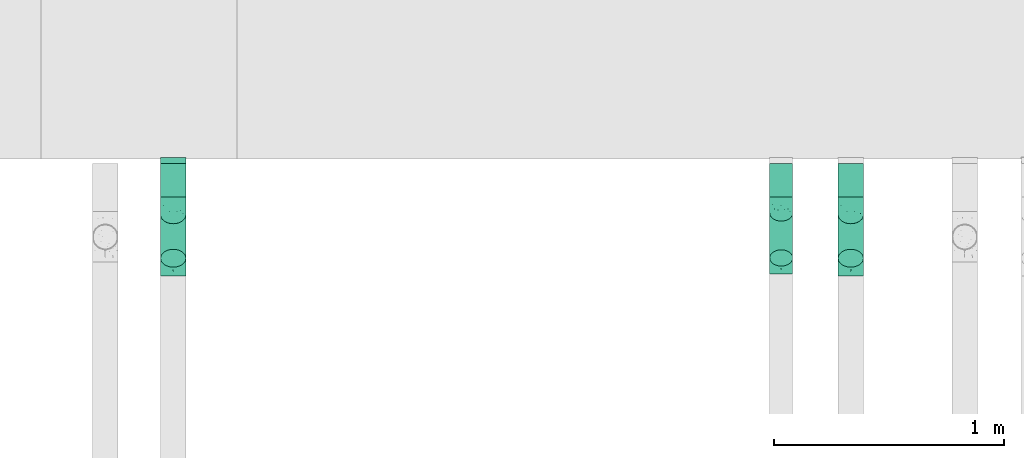
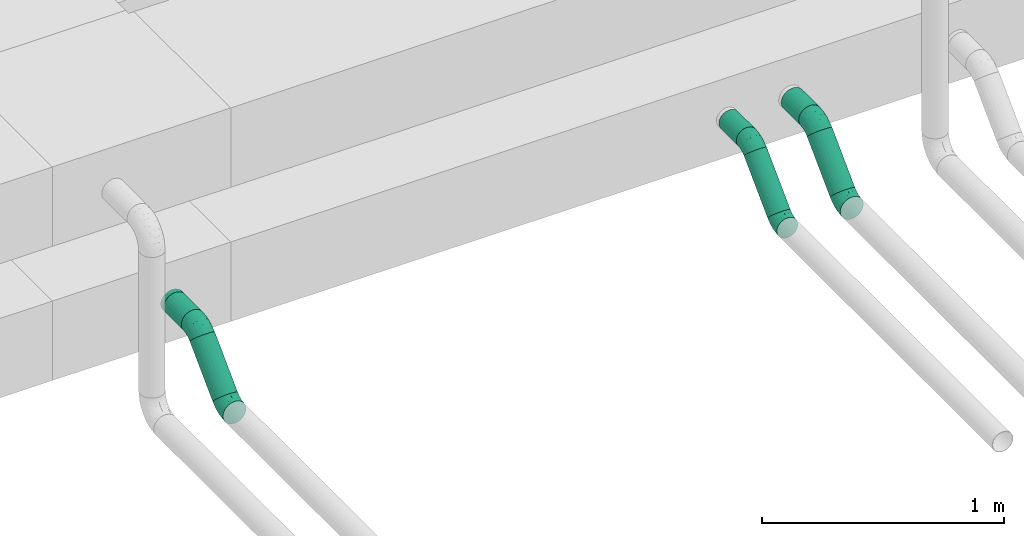
# One storey, part 47 of 91: 7 flow fittings, 6 flow segments.
"""IFC2X3 building model written with IfcOpenShell, lengths in millimetres."""

from ifc_helpers import new_model, entity, si_unit, converted_unit, derived_unit, direction, frame, origin_with_axes, origin_2d_with_axis, place, context, subcontext, project, spatial, hollow_circle, extrude, open_shell, surface_model, source, transform, mapped, material, layer, layer_set, layer_usage, type_object, element, save


model = new_model("IFC2X3")

# Units and contexts
model_context = context("Model", 3, precision=1e-05, world=origin_with_axes(), true_north=direction((0.0, 1.0)))
body_context = subcontext(model_context, "Body", "Model", "MODEL_VIEW")
ifc_project = project(units=[si_unit("AREAUNIT", "SQUARE_METRE"), si_unit("VOLUMEUNIT", "CUBIC_METRE", prefix="DECI"), si_unit("TIMEUNIT", "SECOND"), si_unit("THERMODYNAMICTEMPERATUREUNIT", "DEGREE_CELSIUS"), si_unit("PRESSUREUNIT", "PASCAL"), si_unit("MASSUNIT", "GRAM", prefix="KILO"), si_unit("LENGTHUNIT", "METRE", prefix="MILLI"), si_unit("POWERUNIT", "WATT"), si_unit("ELECTRICCURRENTUNIT", "AMPERE"), si_unit("ELECTRICVOLTAGEUNIT", "VOLT"), derived_unit("VOLUMETRICFLOWRATEUNIT", [(si_unit("VOLUMEUNIT", "CUBIC_METRE", prefix="DECI"), 1), (si_unit("TIMEUNIT", "SECOND"), -1)]), derived_unit("LINEARVELOCITYUNIT", [(si_unit("LENGTHUNIT", "METRE"), 1), (si_unit("TIMEUNIT", "SECOND"), -1)]), derived_unit("MASSDENSITYUNIT", [(si_unit("MASSUNIT", "GRAM", prefix="KILO"), 1), (si_unit("VOLUMEUNIT", "CUBIC_METRE"), -1)]), converted_unit("PLANEANGLEUNIT", "DEGREE", entity("IfcRatioMeasure", 0.01745), si_unit("PLANEANGLEUNIT", "RADIAN"), dimensions=[0, 0, 0, 0, 0, 0, 0])], contexts=[model_context])

# Site, building, storey
site_placement = place(None, origin_with_axes())
site = spatial("IfcSite", under=ifc_project, at=site_placement, CompositionType="ELEMENT")
building_placement = place(site_placement, origin_with_axes())
building = spatial("IfcBuilding", under=site, at=building_placement, Name="mc-building", CompositionType="ELEMENT")
storey_placement = place(building_placement, frame((0.0, 0.0, 8700.0), z_axis=(0.0, 0.0, 1.0), x_axis=(1.0, 0.0, 0.0)))
storey = spatial("IfcBuildingStorey", under=building, at=storey_placement, CompositionType="ELEMENT", Elevation=8700.0)

# Flow segments
ifc_material = material(Name="FZ1")
ifc_layer = layer(ifc_material, 0.0)
ifc_layer_set = layer_set([ifc_layer], Name="FZ1")
ifc_layer_usage = layer_usage(ifc_layer_set, "AXIS1", "POSITIVE", 0.0)
duct_segment_type = type_object("IfcDuctSegmentType", PredefinedType="RIGIDSEGMENT")
shared_shape_1 = source(origin_with_axes(), body_context, "Body", "SweptSolid", [
    extrude(hollow_circle(Radius=55.0, WallThickness=2.0, at=origin_2d_with_axis()), frame((0.0, 0.0, 0.0), z_axis=(1.0, 0.0, 0.0), x_axis=(0.0, 1.0, 0.0)), (0.0, 0.0, 1.0), 266.7),
])
for number, where, z_axis, x_axis in (
    (1, (23048.85991, 2708.27872, 635.78175), (0.0, -0.707107, 0.707107), (0.0, -0.707107, -0.707107)),
    (2, (25991.68775, 2708.27872, 635.78175), (0.0, -0.707107, 0.707107), (0.0, -0.707107, -0.707107)),
):
    element("IfcFlowSegment", number, at=place(storey_placement, frame(where, z_axis=z_axis, x_axis=x_axis)), inside=storey, type_object=duct_segment_type, material=ifc_layer_usage, context=body_context, shape_type="MappedRepresentation", body=[
        mapped(shared_shape_1, transform((0.0, 0.0, 0.0), scale=1.0)),
    ])

# Flow fittings
duct_fitting_type_1 = type_object("IfcDuctFittingType", Name="BU", PredefinedType="BEND")
shared_shape_2 = source(origin_with_axes(), body_context, "Body", "SurfaceModel", [
    surface_model("IfcShellBasedSurfaceModel", [(-45.56349, 0.0, -55.0), (-45.56349, -14.23505, -53.12592), (-45.56349, 14.23505, -53.12592), (-45.56349, 53.12592, 14.23505), (-45.56349, 27.5, -47.63139), (-45.56349, 38.89087, -38.89087), (-45.56349, 47.63139, -27.5), (-45.56349, -55.0, 0.0), (-45.56349, -53.12592, 14.23505), (-45.56349, -38.89087, -38.89087), (-45.56349, -27.5, -47.63139), (-45.56349, -53.12592, -14.23505), (-45.56349, -47.63139, -27.5), (-45.56349, 53.12592, -14.23505), (-45.56349, 47.63139, 27.5), (-45.56349, 38.89087, 38.89087), (-45.56349, -14.23505, 53.12592), (-45.56349, 27.5, 47.63139), (-45.56349, 14.23505, 53.12592), (-45.56349, -47.63139, 27.5), (-45.56349, -38.89087, 38.89087), (-45.56349, -27.5, 47.63139), (-45.56349, 0.0, 55.0), (-45.56349, 55.0, 0.0), (22.15256, 42.28395, -53.12592), (-6.67262, 71.10913, 0.0), (32.21826, 32.21826, -55.0), (12.77282, 51.66369, -47.63139), (-1.46223, 65.89874, -27.5), (4.71825, 59.71825, -38.89087), (59.71825, 4.71825, -38.89087), (69.78395, -5.34744, 14.23505), (51.66369, 12.77282, -47.63139), (42.28395, 22.15256, -53.12592), (65.89874, -1.46223, -27.5), (69.78395, -5.34744, -14.23505), (71.10913, -6.67262, 0.0), (-5.34744, 69.78395, -14.23505), (-5.34744, 69.78395, 14.23505), (-1.46223, 65.89874, 27.5), (4.71825, 59.71825, 38.89087), (32.21826, 32.21826, 55.0), (12.77282, 51.66369, 47.63139), (22.15256, 42.28395, 53.12592), (59.71825, 4.71825, 38.89087), (65.89874, -1.46223, 27.5), (42.28395, 22.15256, 53.12592), (51.66369, 12.77282, 47.63139), (-20.16649, 48.68621, 33.48188), (-26.97111, 35.77503, 43.63444), (-7.30443, 43.73336, 43.63444), (-17.0934, 3.74816, 55.0), (-18.00408, 15.44793, 53.78143), (-30.11707, 22.39897, 50.81337), (-7.49776, 55.63651, 33.48188), (-15.97018, 58.74288, 21.04759), (-31.18231, 52.58712, 21.04759), (-18.35174, 61.03934, 10.51509), (-28.67677, 56.60048, 10.47121), (-34.03924, 44.64267, 33.48188), (-11.52288, 27.81868, 50.81338), (1.19951, 23.16465, 53.81115), (-33.77926, 57.34403, 0.0), (5.4586, 37.12132, 50.81809), (-24.5159, 59.18663, 0.0), (-16.66281, 64.4339, 0.0), (9.43651, 14.73721, 55.0), (-6.22531, 44.36822, -43.63444), (5.4586, 37.12132, -50.81809), (-34.03924, 44.64267, -33.48188), (9.43651, 14.73721, -55.0), (-17.0934, 3.74816, -55.0), (1.19951, 23.16465, -53.81115), (-11.52288, 27.81868, -50.81338), (-30.11707, 22.39897, -50.81337), (-25.75914, 36.08917, -43.63444), (-30.24487, 52.83011, -21.04759), (-20.16649, 48.68621, -33.48188), (-7.49776, 55.63651, -33.48188), (-18.00408, 15.44793, -53.78143), (-28.68366, 56.62226, -10.35271), (-14.15883, 63.53074, -10.87592), (-15.13548, 59.23394, -21.04759), (3.19797, -7.72059, -52.16847), (3.1272, -18.04126, -47.9241), (13.63233, -32.91136, -32.06475), (45.23618, -22.99734, -20.4997), (16.67434, -40.25541, -15.9539), (-17.3935, -51.68264, -9.80849), (-2.85835, -49.37776, 0.0), (48.84421, -24.24609, -9.80849), (-16.38424, -42.76862, -30.85433), (-6.97383, -29.41689, -42.70541), (41.82739, -18.65658, -30.85433), (-15.72523, -48.24839, -20.4997), (29.28945, -13.63928, -42.80781), (26.81493, -3.56603, -49.15704), (36.93651, -32.89419, 0.0), (-15.72523, -48.24839, 20.4997), (-17.3935, -51.68264, 9.80849), (-16.38424, -42.76862, 30.85433), (16.67434, -40.25541, 15.9539), (3.19797, -7.72059, 52.16847), (10.54583, -14.96836, 47.9241), (13.63233, -32.91136, 32.06475), (45.23618, -22.99734, 20.4997), (41.82739, -18.65658, 30.85433), (-11.06635, -30.3552, 42.80781), (25.73213, -15.86964, 42.70541), (-16.43945, -21.48258, 49.15704), (48.84421, -24.24609, 9.80849)], [open_shell([[[0, 1, 2]], [[2, 3, 4]], [[5, 3, 6]], [[4, 3, 5]], [[2, 7, 8]], [[9, 7, 10]], [[1, 10, 7]], [[11, 7, 12]], [[9, 12, 7]], [[7, 2, 1]], [[13, 6, 3]], [[14, 3, 2]], [[15, 14, 2]], [[16, 17, 2]], [[2, 17, 15]], [[16, 18, 17]], [[19, 20, 2]], [[19, 2, 8]], [[20, 21, 2]], [[2, 21, 16]], [[16, 22, 18]], [[23, 13, 3]], [[24, 25, 26]], [[27, 25, 24]], [[28, 25, 29]], [[29, 25, 27]], [[30, 26, 31]], [[26, 30, 32]], [[32, 33, 26]], [[34, 31, 35]], [[31, 34, 30]], [[35, 31, 36]], [[37, 25, 28]], [[26, 38, 39]], [[26, 39, 40]], [[41, 40, 42]], [[26, 40, 41]], [[42, 43, 41]], [[26, 44, 45]], [[31, 26, 45]], [[46, 47, 26]], [[47, 44, 26]], [[46, 26, 41]], [[26, 25, 38]], [[48, 49, 50]], [[22, 51, 52]], [[17, 49, 15]], [[53, 17, 18]], [[49, 17, 53]], [[54, 50, 40]], [[48, 55, 56]], [[55, 57, 58]], [[59, 14, 15]], [[60, 53, 52]], [[50, 49, 60]], [[58, 3, 56]], [[52, 51, 61]], [[62, 23, 3]], [[63, 50, 60]], [[50, 42, 40]], [[3, 58, 62]], [[43, 61, 41]], [[62, 58, 64]], [[48, 59, 49]], [[14, 56, 3]], [[40, 39, 54]], [[57, 64, 58]], [[39, 38, 55]], [[63, 60, 61]], [[54, 55, 48]], [[65, 57, 38]], [[56, 14, 59]], [[38, 25, 65]], [[60, 52, 61]], [[49, 59, 15]], [[55, 58, 56]], [[56, 59, 48]], [[55, 54, 39]], [[50, 54, 48]], [[18, 22, 52]], [[49, 53, 60]], [[18, 52, 53]], [[61, 51, 66]], [[41, 61, 66]], [[63, 61, 43]], [[43, 42, 63]], [[50, 63, 42]], [[38, 57, 55]], [[64, 57, 65]], [[67, 27, 68]], [[69, 5, 6]], [[70, 71, 72]], [[73, 74, 75]], [[76, 77, 69]], [[29, 78, 28]], [[2, 79, 0]], [[13, 23, 62]], [[2, 74, 79]], [[5, 75, 4]], [[77, 78, 67]], [[13, 62, 80]], [[64, 80, 62]], [[81, 80, 64]], [[67, 73, 75]], [[82, 77, 76]], [[81, 64, 65]], [[76, 69, 6]], [[82, 76, 80]], [[24, 72, 68]], [[74, 2, 4]], [[27, 67, 29]], [[26, 70, 72]], [[69, 75, 5]], [[82, 28, 78]], [[72, 71, 79]], [[6, 13, 76]], [[77, 67, 75]], [[13, 80, 76]], [[82, 37, 28]], [[81, 25, 37]], [[82, 81, 37]], [[75, 69, 77]], [[67, 78, 29]], [[82, 78, 77]], [[75, 74, 4]], [[79, 74, 73]], [[79, 73, 72]], [[79, 71, 0]], [[68, 72, 73]], [[26, 72, 24]], [[67, 68, 73]], [[27, 24, 68]], [[80, 81, 82]], [[25, 81, 65]], [[1, 83, 84]], [[85, 86, 87]], [[0, 71, 1]], [[88, 87, 89]], [[90, 86, 35]], [[91, 92, 85]], [[11, 88, 7]], [[30, 34, 93]], [[11, 12, 94]], [[92, 91, 9]], [[85, 94, 91]], [[94, 85, 87]], [[95, 93, 85]], [[85, 92, 95]], [[83, 71, 70]], [[12, 9, 91]], [[70, 26, 33]], [[96, 84, 83]], [[1, 71, 83]], [[95, 96, 32]], [[95, 30, 93]], [[95, 32, 30]], [[97, 89, 87]], [[34, 86, 93]], [[36, 97, 90]], [[94, 88, 11]], [[34, 35, 86]], [[90, 87, 86]], [[93, 86, 85]], [[32, 96, 33]], [[84, 10, 1]], [[33, 83, 70]], [[94, 12, 91]], [[10, 92, 9]], [[87, 88, 94]], [[7, 88, 89]], [[36, 90, 35]], [[87, 90, 97]], [[84, 95, 92]], [[33, 96, 83]], [[95, 84, 96]], [[10, 84, 92]], [[8, 98, 19]], [[7, 89, 99]], [[19, 98, 100]], [[101, 98, 99]], [[46, 102, 103]], [[104, 105, 106]], [[100, 98, 104]], [[107, 104, 108]], [[16, 51, 22]], [[51, 16, 102]], [[107, 20, 100]], [[107, 109, 21]], [[21, 20, 107]], [[103, 47, 46]], [[101, 89, 97]], [[105, 110, 31]], [[44, 47, 108]], [[105, 104, 101]], [[107, 100, 104]], [[31, 110, 36]], [[109, 16, 21]], [[108, 106, 44]], [[105, 45, 106]], [[41, 66, 46]], [[102, 66, 51]], [[46, 66, 102]], [[104, 98, 101]], [[99, 98, 8]], [[106, 108, 104]], [[110, 101, 97]], [[45, 44, 106]], [[105, 31, 45]], [[20, 19, 100]], [[109, 103, 102]], [[101, 110, 105]], [[36, 110, 97]], [[7, 99, 8]], [[101, 99, 89]], [[103, 107, 108]], [[16, 109, 102]], [[107, 103, 109]], [[47, 103, 108]]])]),
])
for number, where, z_axis, x_axis, name in (
    (3, (23048.85991, 2740.49698, 668.0), (-1.0, 0.0, 0.0), (0.0, 0.707107, 0.707107), "BU"),
    (4, (23048.85991, 2487.49698, 415.0), (1.0, 0.0, 0.0), (0.0, 1.0, 0.0), "BU"),
    (5, (25991.68775, 2740.49698, 668.0), (-1.0, 0.0, 0.0), (0.0, 0.707107, 0.707107), "BU"),
    (6, (25991.68775, 2487.49698, 415.0), (1.0, 0.0, 0.0), (0.0, 1.0, 0.0), "BU"),
):
    element("IfcFlowFitting", number, at=place(storey_placement, frame(where, z_axis=z_axis, x_axis=x_axis)), inside=storey, type_object=duct_fitting_type_1, Name=name, context=body_context, shape_type="MappedRepresentation", body=[
        mapped(shared_shape_2, transform((0.0, 0.0, 0.0), scale=1.0)),
    ])

# Flow segment
shared_shape_3 = source(origin_with_axes(), body_context, "Body", "SweptSolid", [
    extrude(hollow_circle(Radius=50.0, WallThickness=2.0, at=origin_2d_with_axis()), frame((0.0, 0.0, 0.0), z_axis=(1.0, 0.0, 0.0), x_axis=(0.0, 1.0, 0.0)), (0.0, 0.0, 1.0), 275.8),
])
flow_segment_1_placement = place(storey_placement, frame((25689.63788, 2716.06909, 639.00862), z_axis=(0.0, -0.707107, 0.707107), x_axis=(0.0, -0.707107, -0.707107)))
element("IfcFlowSegment", 7, at=flow_segment_1_placement, inside=storey, type_object=duct_segment_type, material=ifc_layer_usage, context=body_context, shape_type="MappedRepresentation", body=[
    mapped(shared_shape_3, transform((0.0, 0.0, 0.0), scale=1.0)),
])

# Flow fittings
shared_shape_4 = source(origin_with_axes(), body_context, "Body", "SurfaceModel", [
    surface_model("IfcShellBasedSurfaceModel", [(-41.0, 0.0, -50.0), (-41.0, -12.94095, -48.29629), (-41.0, 12.94095, -48.29629), (-41.0, 48.29629, 12.94095), (-41.0, 25.0, -43.30127), (-41.0, 43.30127, -25.0), (-41.0, 35.35534, -35.35534), (-41.0, -50.0, 0.0), (-41.0, -48.29629, 12.94095), (-41.0, -35.35534, -35.35534), (-41.0, -25.0, -43.30127), (-41.0, -48.29629, -12.94095), (-41.0, -43.30127, -25.0), (-41.0, 48.29629, -12.94095), (-41.0, 43.30127, 25.0), (-41.0, 35.35534, 35.35534), (-41.0, -12.94095, 48.29629), (-41.0, 25.0, 43.30127), (-41.0, 12.94095, 48.29629), (-41.0, -43.30127, 25.0), (-41.0, -35.35534, 35.35534), (-41.0, -25.0, 43.30127), (-41.0, 0.0, 50.0), (-41.0, 50.0, 0.0), (19.84074, 38.14201, -48.29629), (-6.36396, 64.34672, 0.0), (28.99138, 28.99138, -50.0), (11.31371, 46.66905, -43.30127), (3.99138, 53.99138, -35.35534), (-1.62724, 59.61, -25.0), (53.99138, 3.99138, -35.35534), (63.14201, -5.15926, 12.94095), (46.66905, 11.31371, -43.30127), (38.14201, 19.84074, -48.29629), (59.61, -1.62724, -25.0), (63.14201, -5.15926, -12.94095), (64.34672, -6.36396, 0.0), (-5.15926, 63.14201, -12.94095), (-5.15926, 63.14201, 12.94095), (-1.62724, 59.61, 25.0), (3.99138, 53.99138, 35.35534), (28.99138, 28.99138, 50.0), (11.31371, 46.66905, 43.30127), (19.84074, 38.14201, 48.29629), (59.61, -1.62724, 25.0), (53.99138, 3.99138, 35.35534), (38.14201, 19.84074, 48.29629), (46.66905, 11.31371, 43.30127), (-18.30109, 44.18276, 30.43807), (-24.345, 32.49227, 39.66767), (-6.72766, 39.62131, 39.66767), (-15.38138, 3.37276, 50.0), (-16.23064, 14.00293, 48.89221), (-27.13444, 20.34725, 46.19398), (-6.97826, 50.39468, 30.43807), (-14.60561, 53.26633, 19.13417), (-28.17337, 47.77599, 19.13417), (-16.73188, 55.37236, 9.57436), (-25.91257, 51.41785, 9.5354), (-30.70005, 40.56879, 30.43807), (-10.44327, 25.21228, 46.19398), (1.0295, 20.93716, 48.91923), (-30.42146, 52.10421, 0.0), (4.80032, 33.56273, 46.19826), (-22.25511, 53.72859, 0.0), (-15.33202, 58.35446, 0.0), (8.49138, 13.26118, 50.0), (-5.76099, 40.19002, -39.66767), (4.80032, 33.56273, -46.19826), (-30.70005, 40.56879, -30.43807), (8.49138, 13.26118, -50.0), (-15.38138, 3.37276, -50.0), (1.0295, 20.93716, -48.91923), (-10.44327, 25.21228, -46.19398), (-27.13444, 20.34725, -46.19398), (-23.25933, 32.77367, -39.66767), (-27.33726, 47.99271, -19.13417), (-18.30109, 44.18276, -30.43807), (-6.97826, 50.39468, -30.43807), (-16.23064, 14.00293, -48.89221), (-25.91896, 51.438, -9.42588), (-13.02367, 57.57988, -9.8805), (-13.86114, 53.70431, -19.13417), (2.93034, -7.07447, -47.43371), (2.81434, -16.4825, -43.57717), (12.42788, -30.00357, -29.13965), (40.96913, -21.08746, -18.63201), (15.19143, -36.67536, -14.49606), (-15.58185, -47.0029, -8.91278), (-2.44043, -44.92353, 0.0), (44.2541, -22.21804, -8.91278), (-14.66706, -38.90004, -28.04813), (-6.17907, -26.78474, -38.81666), (37.87766, -17.1353, -28.04813), (-14.05847, -43.88064, -18.63201), (26.52839, -12.54993, -38.91078), (24.22802, -3.41873, -44.68725), (33.49138, -30.04009, 0.0), (-14.05847, -43.88064, 18.63201), (-15.58185, -47.0029, 8.91278), (-14.66706, -38.90004, 28.04813), (15.19143, -36.67536, 14.49606), (2.93034, -7.07447, 47.43371), (9.66485, -13.64492, 43.57717), (12.42788, -30.00357, 29.13965), (40.96913, -21.08746, 18.63201), (37.87766, -17.1353, 28.04813), (-9.88426, -27.63255, 38.91078), (23.30894, -14.57041, 38.81666), (-14.71439, -19.5492, 44.68725), (44.2541, -22.21804, 8.91278)], [open_shell([[[0, 1, 2]], [[2, 3, 4]], [[5, 6, 3]], [[3, 6, 4]], [[2, 7, 8]], [[9, 7, 10]], [[1, 10, 7]], [[11, 7, 12]], [[9, 12, 7]], [[7, 2, 1]], [[13, 5, 3]], [[14, 3, 2]], [[15, 14, 2]], [[16, 17, 2]], [[15, 2, 17]], [[18, 17, 16]], [[8, 19, 2]], [[2, 19, 20]], [[2, 20, 21]], [[16, 2, 21]], [[16, 22, 18]], [[23, 13, 3]], [[24, 25, 26]], [[27, 25, 24]], [[25, 28, 29]], [[27, 28, 25]], [[30, 26, 31]], [[26, 30, 32]], [[32, 33, 26]], [[34, 31, 35]], [[34, 30, 31]], [[36, 35, 31]], [[37, 25, 29]], [[26, 38, 39]], [[26, 39, 40]], [[41, 40, 42]], [[40, 41, 26]], [[41, 42, 43]], [[44, 31, 26]], [[45, 44, 26]], [[46, 47, 26]], [[45, 26, 47]], [[26, 41, 46]], [[25, 38, 26]], [[48, 49, 50]], [[22, 51, 52]], [[17, 49, 15]], [[53, 17, 18]], [[49, 17, 53]], [[54, 50, 40]], [[48, 55, 56]], [[55, 57, 58]], [[59, 14, 15]], [[60, 53, 52]], [[50, 49, 60]], [[58, 3, 56]], [[52, 51, 61]], [[62, 23, 3]], [[63, 50, 60]], [[50, 42, 40]], [[3, 58, 62]], [[43, 61, 41]], [[62, 58, 64]], [[48, 59, 49]], [[14, 56, 3]], [[40, 39, 54]], [[57, 64, 58]], [[39, 38, 55]], [[63, 60, 61]], [[54, 55, 48]], [[65, 57, 38]], [[56, 14, 59]], [[38, 25, 65]], [[60, 52, 61]], [[49, 59, 15]], [[55, 58, 56]], [[56, 59, 48]], [[55, 54, 39]], [[50, 54, 48]], [[18, 22, 52]], [[49, 53, 60]], [[18, 52, 53]], [[61, 51, 66]], [[41, 61, 66]], [[63, 61, 43]], [[43, 42, 63]], [[50, 63, 42]], [[38, 57, 55]], [[64, 57, 65]], [[67, 27, 68]], [[69, 6, 5]], [[70, 71, 72]], [[73, 74, 75]], [[76, 77, 69]], [[28, 78, 29]], [[2, 79, 0]], [[13, 23, 62]], [[2, 74, 79]], [[6, 75, 4]], [[77, 78, 67]], [[13, 62, 80]], [[64, 80, 62]], [[81, 80, 64]], [[67, 73, 75]], [[82, 77, 76]], [[81, 64, 65]], [[76, 69, 5]], [[82, 76, 80]], [[24, 72, 68]], [[74, 2, 4]], [[27, 67, 28]], [[26, 70, 72]], [[69, 75, 6]], [[82, 29, 78]], [[72, 71, 79]], [[5, 13, 76]], [[77, 67, 75]], [[13, 80, 76]], [[82, 37, 29]], [[81, 25, 37]], [[82, 81, 37]], [[75, 69, 77]], [[67, 78, 28]], [[82, 78, 77]], [[75, 74, 4]], [[79, 74, 73]], [[79, 73, 72]], [[79, 71, 0]], [[68, 72, 73]], [[26, 72, 24]], [[67, 68, 73]], [[27, 24, 68]], [[80, 81, 82]], [[25, 81, 65]], [[1, 83, 84]], [[85, 86, 87]], [[0, 71, 1]], [[88, 87, 89]], [[90, 86, 35]], [[91, 92, 85]], [[11, 88, 7]], [[30, 34, 93]], [[11, 12, 94]], [[92, 91, 9]], [[85, 94, 91]], [[94, 85, 87]], [[95, 93, 85]], [[85, 92, 95]], [[83, 71, 70]], [[12, 9, 91]], [[70, 26, 33]], [[96, 84, 83]], [[1, 71, 83]], [[95, 96, 32]], [[95, 30, 93]], [[95, 32, 30]], [[97, 89, 87]], [[34, 86, 93]], [[36, 97, 90]], [[94, 88, 11]], [[34, 35, 86]], [[90, 87, 86]], [[93, 86, 85]], [[32, 96, 33]], [[84, 10, 1]], [[33, 83, 70]], [[94, 12, 91]], [[10, 92, 9]], [[87, 88, 94]], [[7, 88, 89]], [[36, 90, 35]], [[87, 90, 97]], [[84, 95, 92]], [[33, 96, 83]], [[95, 84, 96]], [[10, 84, 92]], [[8, 98, 19]], [[7, 89, 99]], [[19, 98, 100]], [[101, 98, 99]], [[46, 102, 103]], [[104, 105, 106]], [[100, 98, 104]], [[107, 104, 108]], [[16, 51, 22]], [[51, 16, 102]], [[107, 20, 100]], [[107, 109, 21]], [[21, 20, 107]], [[103, 47, 46]], [[101, 89, 97]], [[105, 110, 31]], [[45, 47, 108]], [[105, 104, 101]], [[107, 100, 104]], [[31, 110, 36]], [[109, 16, 21]], [[108, 106, 45]], [[105, 44, 106]], [[41, 66, 46]], [[102, 66, 51]], [[46, 66, 102]], [[104, 98, 101]], [[99, 98, 8]], [[106, 108, 104]], [[110, 101, 97]], [[44, 45, 106]], [[105, 31, 44]], [[20, 19, 100]], [[109, 103, 102]], [[101, 110, 105]], [[36, 110, 97]], [[7, 99, 8]], [[101, 99, 89]], [[103, 107, 108]], [[16, 109, 102]], [[107, 103, 109]], [[47, 103, 108]]])]),
])
for number, where, z_axis, x_axis, name in (
    (8, (25689.63788, 2745.06047, 668.0), (-1.0, 0.0, 0.0), (0.0, 0.707107, 0.707107), "BU"),
    (9, (25689.63788, 2492.06047, 415.0), (1.0, 0.0, 0.0), (0.0, 1.0, 0.0), "BU"),
):
    element("IfcFlowFitting", number, at=place(storey_placement, frame(where, z_axis=z_axis, x_axis=x_axis)), inside=storey, type_object=duct_fitting_type_1, Name=name, context=body_context, shape_type="MappedRepresentation", body=[
        mapped(shared_shape_4, transform((0.0, 0.0, 0.0), scale=1.0)),
    ])
duct_fitting_type_2 = type_object("IfcDuctFittingType", Name="CC", PredefinedType="CONNECTOR")
shared_shape_5 = source(origin_with_axes(), body_context, "Body", "SurfaceModel", [
    surface_model("IfcShellBasedSurfaceModel", [(-6.096, -38.89087, -38.89087), (-6.096, -55.0, 0.0), (-6.096, -27.5, -47.63139), (-6.096, 47.63139, -27.5), (-6.096, 53.12592, 14.23505), (-6.096, 53.12592, -14.23505), (-6.096, 55.0, 0.0), (-6.096, -53.12592, -14.23505), (-6.096, -47.63139, -27.5), (20.0, 38.89087, -38.89087), (20.0, 55.0, 0.0), (20.0, 27.5, -47.63139), (20.0, 53.12592, -14.23505), (20.0, 47.63139, -27.5), (20.0, -47.63139, -27.5), (20.0, -53.12592, 14.23505), (20.0, -53.12592, -14.23505), (20.0, -55.0, 0.0), (-6.096, 0.0, -55.0), (-6.096, -14.23505, -53.12592), (-6.096, 14.23505, -53.12592), (-6.096, 27.5, -47.63139), (-6.096, 38.89087, -38.89087), (-6.096, -53.12592, 14.23505), (-6.096, 47.63139, 27.5), (-6.096, 38.89087, 38.89087), (-6.096, -14.23505, 53.12592), (-6.096, 27.5, 47.63139), (-6.096, 14.23505, 53.12592), (-6.096, -47.63139, 27.5), (-6.096, -38.89087, 38.89087), (-6.096, -27.5, 47.63139), (-6.096, 0.0, 55.0), (0.0, 0.0, 55.0), (0.0, 14.23505, 53.12592), (0.0, 27.5, 47.63139), (0.0, 38.89087, 38.89087), (0.0, 47.63139, 27.5), (0.0, 53.12592, 14.23505), (0.0, 55.0, 0.0), (0.0, 53.12592, -14.23505), (0.0, 47.63139, -27.5), (0.0, 38.89087, -38.89087), (0.0, 27.5, -47.63139), (0.0, 14.23505, -53.12592), (0.0, 0.0, -55.0), (0.0, -14.23505, -53.12592), (0.0, -27.5, -47.63139), (0.0, -38.89087, -38.89087), (0.0, -47.63139, -27.5), (0.0, -53.12592, -14.23505), (0.0, -55.0, 0.0), (0.0, -53.12592, 14.23505), (0.0, -47.63139, 27.5), (0.0, -38.89087, 38.89087), (0.0, -27.5, 47.63139), (0.0, -14.23505, 53.12592), (20.0, 0.0, -55.0), (20.0, 14.23505, -53.12592), (20.0, -38.89087, -38.89087), (20.0, -27.5, -47.63139), (20.0, -14.23505, -53.12592), (20.0, 53.12592, 14.23505), (20.0, 47.63139, 27.5), (20.0, 38.89087, 38.89087), (20.0, 0.0, 55.0), (20.0, 27.5, 47.63139), (20.0, 14.23505, 53.12592), (20.0, -38.89087, 38.89087), (20.0, -47.63139, 27.5), (20.0, -14.23505, 53.12592), (20.0, -27.5, 47.63139)], [open_shell([[[0, 1, 2]], [[3, 4, 5]], [[6, 5, 4]], [[7, 1, 8]], [[9, 10, 11]], [[12, 10, 13]], [[14, 15, 16]], [[17, 16, 15]], [[18, 19, 20]], [[20, 4, 21]], [[3, 22, 4]], [[21, 4, 22]], [[20, 1, 23]], [[19, 2, 1]], [[0, 8, 1]], [[1, 20, 19]], [[20, 24, 4]], [[25, 24, 20]], [[26, 27, 20]], [[27, 25, 20]], [[26, 28, 27]], [[20, 29, 30]], [[29, 20, 23]], [[30, 31, 20]], [[20, 31, 26]], [[26, 32, 28]], [[32, 33, 34]], [[28, 34, 35]], [[32, 34, 28]], [[27, 36, 25]], [[27, 28, 35]], [[36, 27, 35]], [[24, 37, 38]], [[4, 38, 39]], [[25, 37, 24]], [[4, 24, 38]], [[6, 4, 39]], [[37, 25, 36]], [[6, 39, 40]], [[5, 40, 41]], [[6, 40, 5]], [[3, 42, 22]], [[3, 5, 41]], [[42, 3, 41]], [[21, 43, 44]], [[20, 44, 45]], [[22, 43, 21]], [[20, 21, 44]], [[18, 20, 45]], [[43, 22, 42]], [[18, 45, 46]], [[19, 46, 47]], [[18, 46, 19]], [[2, 48, 0]], [[2, 19, 47]], [[48, 2, 47]], [[8, 49, 50]], [[7, 50, 51]], [[0, 49, 8]], [[7, 8, 50]], [[1, 7, 51]], [[49, 0, 48]], [[1, 51, 52]], [[23, 52, 53]], [[1, 52, 23]], [[29, 54, 30]], [[29, 23, 53]], [[54, 29, 53]], [[31, 55, 56]], [[26, 56, 33]], [[30, 55, 31]], [[26, 31, 56]], [[32, 26, 33]], [[55, 30, 54]], [[10, 57, 58]], [[11, 10, 58]], [[10, 9, 13]], [[59, 57, 15]], [[57, 59, 60]], [[60, 61, 57]], [[59, 15, 14]], [[62, 63, 57]], [[57, 63, 64]], [[65, 64, 66]], [[65, 57, 64]], [[67, 65, 66]], [[68, 69, 57]], [[15, 57, 69]], [[70, 71, 57]], [[71, 68, 57]], [[70, 57, 65]], [[10, 62, 57]], [[33, 65, 67]], [[34, 67, 66]], [[33, 67, 34]], [[35, 64, 36]], [[35, 34, 66]], [[64, 35, 66]], [[37, 63, 62]], [[38, 62, 10]], [[36, 63, 37]], [[38, 37, 62]], [[39, 38, 10]], [[63, 36, 64]], [[39, 10, 12]], [[40, 12, 13]], [[39, 12, 40]], [[41, 9, 42]], [[41, 40, 13]], [[9, 41, 13]], [[43, 11, 58]], [[44, 58, 57]], [[42, 11, 43]], [[44, 43, 58]], [[45, 44, 57]], [[11, 42, 9]], [[45, 57, 61]], [[46, 61, 60]], [[45, 61, 46]], [[47, 59, 48]], [[47, 46, 60]], [[59, 47, 60]], [[49, 14, 16]], [[50, 16, 17]], [[48, 14, 49]], [[50, 49, 16]], [[51, 50, 17]], [[14, 48, 59]], [[51, 17, 15]], [[52, 15, 69]], [[51, 15, 52]], [[53, 68, 54]], [[53, 52, 69]], [[68, 53, 69]], [[55, 71, 70]], [[56, 70, 65]], [[54, 71, 55]], [[56, 55, 70]], [[33, 56, 65]], [[71, 54, 68]], [[65, 57, 66]], [[57, 64, 66]], [[65, 66, 67]], [[69, 15, 57]]])]),
])
flow_fitting_placement = place(storey_placement, frame((23048.85991, 2951.20513, 668.0), z_axis=(0.0, 0.0, -1.0), x_axis=(0.0, -1.0, 0.0)))
element("IfcFlowFitting", 10, at=flow_fitting_placement, inside=storey, type_object=duct_fitting_type_2, Name="CC", context=body_context, shape_type="MappedRepresentation", body=[
    mapped(shared_shape_5, transform((0.0, 0.0, 0.0), scale=1.0)),
])

# Flow segments
shared_shape_6 = source(origin_with_axes(), body_context, "Body", "SweptSolid", [
    extrude(hollow_circle(Radius=55.0, WallThickness=2.0, at=origin_2d_with_axis()), frame((0.0, 0.0, 0.0), z_axis=(1.0, 0.0, 0.0), x_axis=(0.0, 1.0, 0.0)), (0.0, 0.0, 1.0), 145.1),
])
for number, where, z_axis, x_axis in (
    (11, (23048.85991, 2931.20513, 668.0), (0.0, 0.0, 1.0), (0.0, -1.0, 0.0)),
    (12, (25991.68775, 2931.20513, 668.0), (0.0, 0.0, 1.0), (0.0, -1.0, 0.0)),
):
    element("IfcFlowSegment", number, at=place(storey_placement, frame(where, z_axis=z_axis, x_axis=x_axis)), inside=storey, type_object=duct_segment_type, material=ifc_layer_usage, context=body_context, shape_type="MappedRepresentation", body=[
        mapped(shared_shape_6, transform((0.0, 0.0, 0.0), scale=1.0)),
    ])
shared_shape_7 = source(origin_with_axes(), body_context, "Body", "SweptSolid", [
    extrude(hollow_circle(Radius=50.0, WallThickness=2.0, at=origin_2d_with_axis()), frame((0.0, 0.0, 0.0), z_axis=(1.0, 0.0, 0.0), x_axis=(0.0, 1.0, 0.0)), (0.0, 0.0, 1.0), 145.1),
])
flow_segment_2_placement = place(storey_placement, frame((25689.63788, 2931.20513, 668.0), z_axis=(0.0, 0.0, 1.0), x_axis=(0.0, -1.0, 0.0)))
element("IfcFlowSegment", 13, at=flow_segment_2_placement, inside=storey, type_object=duct_segment_type, material=ifc_layer_usage, context=body_context, shape_type="MappedRepresentation", body=[
    mapped(shared_shape_7, transform((0.0, 0.0, 0.0), scale=1.0)),
])

save(model, "model.ifc")
